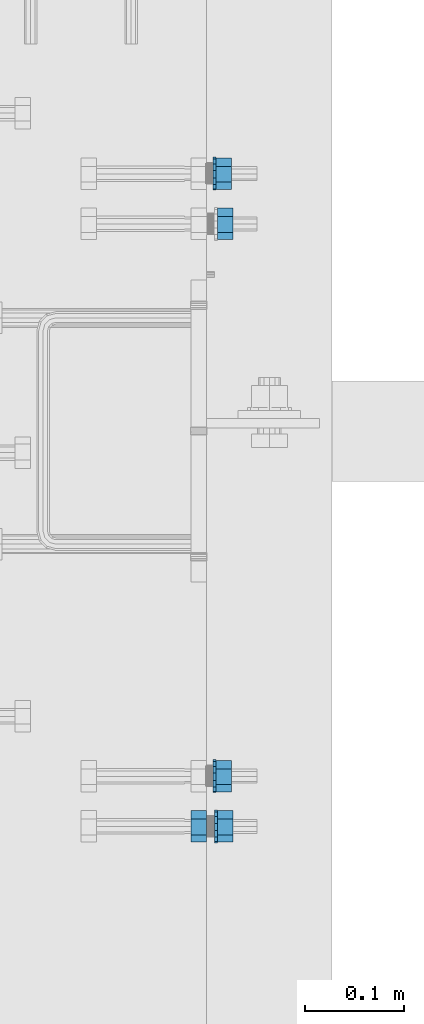
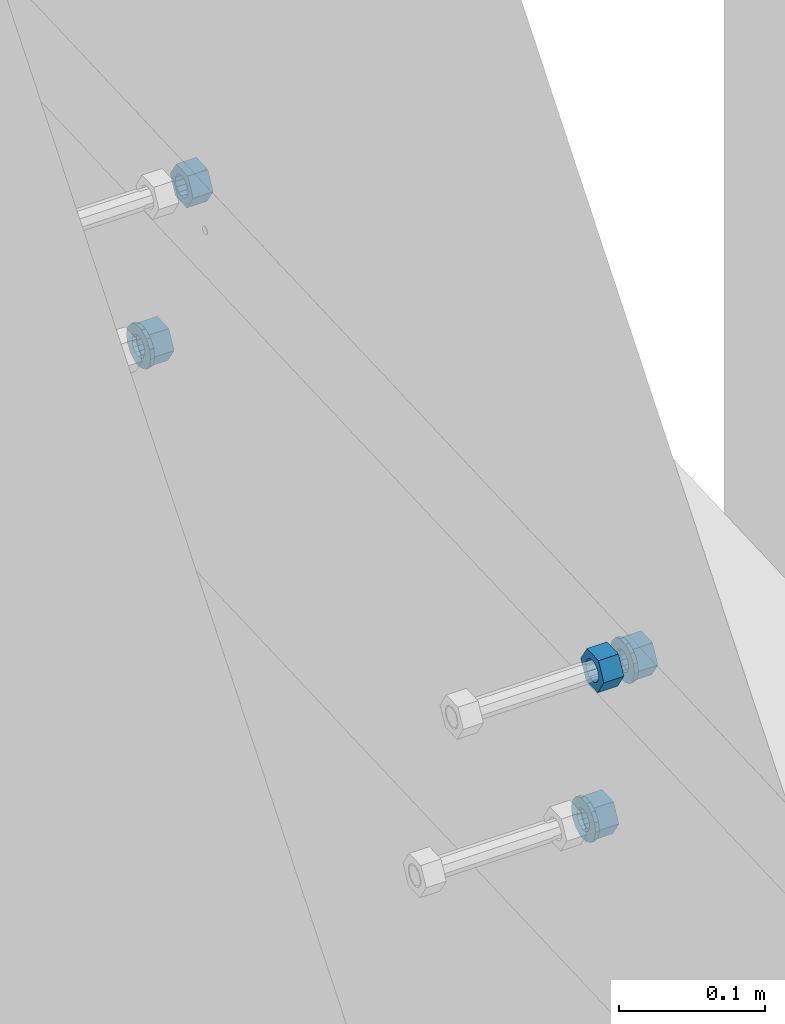
# One storey, part 717 of 975: 8 beams.
"""IFC2X3 building model written with IfcOpenShell, lengths in millimetres."""

from ifc_helpers import new_model, si_unit, frame, origin_with_axes, place, context, subcontext, project, spatial, faceted_brep, material, type_object, element, save


model = new_model("IFC2X3")

# Units and contexts
model_context = context("Model", 3, precision=1e-05, world=origin_with_axes())
body_context = subcontext(model_context, "Body", "Model", "MODEL_VIEW")
ifc_project = project(units=[si_unit("LENGTHUNIT", "METRE", prefix="MILLI"), si_unit("AREAUNIT", "SQUARE_METRE"), si_unit("VOLUMEUNIT", "CUBIC_METRE"), si_unit("MASSUNIT", "GRAM", prefix="KILO"), si_unit("TIMEUNIT", "SECOND"), si_unit("PLANEANGLEUNIT", "RADIAN"), si_unit("SOLIDANGLEUNIT", "STERADIAN"), si_unit("THERMODYNAMICTEMPERATUREUNIT", "DEGREE_CELSIUS"), si_unit("LUMINOUSINTENSITYUNIT", "LUMEN")], contexts=[model_context])

# Site, building, storey
site_placement = place(None, origin_with_axes())
site = spatial("IfcSite", under=ifc_project, at=site_placement, CompositionType="ELEMENT")
building_placement = place(site_placement, origin_with_axes())
building = spatial("IfcBuilding", under=site, at=building_placement, Name="Undefined", CompositionType="ELEMENT")
storey_placement = place(building_placement, origin_with_axes())
storey = spatial("IfcBuildingStorey", under=building, at=storey_placement, Name="Undefined", CompositionType="ELEMENT", Elevation=0.0)

# Beams
ifc_material_1 = material(Name="STEEL/F1554-36")
beam_type_1 = type_object("IfcBeamType", Name="5/8_HEAVY_HEX_NUT", PredefinedType="NOTDEFINED")
beam_1_placement = place(storey_placement, frame((29986.2872319715, 2821.85900178014, 7106.48806988909), z_axis=(-7.0905516622588e-09, -0.0430877640020049, 0.999071291046494), x_axis=(-0.999999999999998, 6.90000001668524e-08, 0.0)))
element("IfcBeam", 1, at=beam_1_placement, inside=storey, type_object=beam_type_1, material=ifc_material_1, Name="HEADED_ANCHOR_BOLT", ObjectType="5/8_HEAVY_HEX_NUT", context=body_context, shape_type="Brep", body=[
    faceted_brep([(-1.09139364212751e-11, -15.8800001144436, -2.72848410531878e-12), (1.45519152283669e-11, -7.94000005722046, -13.7500000000036), (15.8750000000146, -7.94000005722137, -13.7500000000045), (15.8749999999891, -15.8800001144446, -2.72848410531878e-12), (2.91038304567337e-11, 7.94000005722319, -13.7500000000027), (15.8750000000291, 7.94000005722319, -13.7500000000027), (2.18278728425503e-11, 15.8800001144436, 9.09494701772928e-13), (15.8750000000218, 15.8800001144427, 9.09494701772928e-13), (-7.27595761418343e-12, 7.94000005722046, 13.7500000000027), (15.8749999999927, 7.94000005722046, 13.7500000000027), (-2.18278728425503e-11, -7.94000005722228, 13.7500000000009), (15.8749999999782, -7.94000005722319, 13.7500000000009), (-7.27595761418343e-12, 0.0, 8.72999954223724), (0.0, 3.78780484388062, 7.86545780435881), (15.875, 3.78780484387971, 7.86545780435881), (15.8749999999927, -9.09494701772928e-13, 8.72999954223724), (7.27595761418343e-12, 6.82538848405238, 5.44306568481716), (15.8750000000073, 6.82538848405238, 5.44306568481716), (1.09139364212751e-11, 8.51112022706275, 1.94260765157742), (15.8750000000109, 8.51112022706093, 1.94260765157651), (1.45519152283669e-11, 8.51112022706184, -1.94260765157651), (15.8750000000146, 8.51112022706184, -1.94260765157651), (2.18278728425503e-11, 6.8253884840542, -5.44306568481716), (15.8750000000218, 6.82538848405238, -5.44306568481716), (1.81898940354586e-11, 3.78780484388153, -7.86545780435881), (15.8750000000182, 3.78780484388062, -7.86545780435881), (1.81898940354586e-11, 9.09494701772928e-13, -8.72999954223997), (15.8750000000182, 9.09494701772928e-13, -8.72999954223997), (1.09139364212751e-11, -3.78780484387971, -7.86545780436063), (15.8750000000109, -3.78780484388062, -7.86545780436063), (3.63797880709171e-12, -6.82538848405238, -5.44306568481807), (15.8750000000036, -6.82538848405329, -5.44306568481807), (0.0, -8.51112022706184, -1.94260765157833), (15.875, -8.51112022706184, -1.94260765157833), (-7.27595761418343e-12, -8.51112022706184, 1.9426076515756), (15.8749999999927, -8.51112022706275, 1.9426076515756), (-1.09139364212751e-11, -6.82538848405329, 5.44306568481534), (15.8749999999927, -6.8253884840542, 5.44306568481534), (-7.27595761418343e-12, -3.78780484388062, 7.8654578043579), (15.8749999999927, -3.78780484388153, 7.8654578043579)], [[[0, 1, 2, 3]], [[1, 4, 5, 2]], [[4, 6, 7, 5]], [[6, 8, 9, 7]], [[8, 10, 11, 9]], [[10, 0, 3, 11]], [[12, 13, 14, 15]], [[13, 16, 17, 14]], [[16, 18, 19, 17]], [[18, 20, 21, 19]], [[20, 22, 23, 21]], [[22, 24, 25, 23]], [[24, 26, 27, 25]], [[26, 28, 29, 27]], [[28, 30, 31, 29]], [[30, 32, 33, 31]], [[32, 34, 35, 33]], [[34, 36, 37, 35]], [[36, 38, 39, 37]], [[38, 12, 15, 39]], [[5, 7, 9, 11, 3, 2], [17, 19, 21, 23, 25, 27, 29, 31, 33, 35, 37, 39, 15, 14]], [[10, 8, 6, 4, 1, 0], [38, 36, 34, 32, 30, 28, 26, 24, 22, 20, 18, 16, 13, 12]]]),
])
beam_2_placement = place(storey_placement, frame((29959.2997837873, 2212.82505215651, 7080.22176473378), z_axis=(3.96407267544419e-09, 0.0430877640020053, -0.999071291046494), x_axis=(-0.999999999999998, 6.90000001668524e-08, 0.0)))
element("IfcBeam", 2, at=beam_2_placement, inside=storey, type_object=beam_type_1, material=ifc_material_1, Name="HEADED_ANCHOR_BOLT", ObjectType="5/8_HEAVY_HEX_NUT", context=body_context, shape_type="Brep", body=[
    faceted_brep([(-1.09139364212751e-11, -15.8800001144436, -2.72848410531878e-12), (1.45519152283669e-11, -7.94000005722046, -13.7500000000036), (15.8750000000146, -7.94000005722137, -13.7500000000045), (15.8749999999891, -15.8800001144446, -2.72848410531878e-12), (2.91038304567337e-11, 7.94000005722319, -13.7500000000027), (15.8750000000291, 7.94000005722319, -13.7500000000027), (2.18278728425503e-11, 15.8800001144436, 9.09494701772928e-13), (15.8750000000218, 15.8800001144427, 9.09494701772928e-13), (-7.27595761418343e-12, 7.94000005722046, 13.7500000000027), (15.8749999999927, 7.94000005722046, 13.7500000000027), (-2.18278728425503e-11, -7.94000005722228, 13.7500000000009), (15.8749999999782, -7.94000005722319, 13.7500000000009), (-7.27595761418343e-12, 0.0, 8.72999954223724), (0.0, 3.78780484388062, 7.86545780435881), (15.875, 3.78780484387971, 7.86545780435881), (15.8749999999927, -9.09494701772928e-13, 8.72999954223724), (7.27595761418343e-12, 6.82538848405238, 5.44306568481716), (15.8750000000073, 6.82538848405238, 5.44306568481716), (1.09139364212751e-11, 8.51112022706275, 1.94260765157742), (15.8750000000109, 8.51112022706093, 1.94260765157651), (1.45519152283669e-11, 8.51112022706184, -1.94260765157651), (15.8750000000146, 8.51112022706184, -1.94260765157651), (2.18278728425503e-11, 6.8253884840542, -5.44306568481716), (15.8750000000218, 6.82538848405238, -5.44306568481716), (1.81898940354586e-11, 3.78780484388153, -7.86545780435881), (15.8750000000182, 3.78780484388062, -7.86545780435881), (1.81898940354586e-11, 9.09494701772928e-13, -8.72999954223997), (15.8750000000182, 9.09494701772928e-13, -8.72999954223997), (1.09139364212751e-11, -3.78780484387971, -7.86545780436063), (15.8750000000109, -3.78780484388062, -7.86545780436063), (3.63797880709171e-12, -6.82538848405238, -5.44306568481807), (15.8750000000036, -6.82538848405329, -5.44306568481807), (0.0, -8.51112022706184, -1.94260765157833), (15.875, -8.51112022706184, -1.94260765157833), (-7.27595761418343e-12, -8.51112022706184, 1.9426076515756), (15.8749999999927, -8.51112022706275, 1.9426076515756), (-1.09139364212751e-11, -6.82538848405329, 5.44306568481534), (15.8749999999927, -6.8253884840542, 5.44306568481534), (-7.27595761418343e-12, -3.78780484388062, 7.8654578043579), (15.8749999999927, -3.78780484388153, 7.8654578043579)], [[[0, 1, 2, 3]], [[1, 4, 5, 2]], [[4, 6, 7, 5]], [[6, 8, 9, 7]], [[8, 10, 11, 9]], [[10, 0, 3, 11]], [[12, 13, 14, 15]], [[13, 16, 17, 14]], [[16, 18, 19, 17]], [[18, 20, 21, 19]], [[20, 22, 23, 21]], [[22, 24, 25, 23]], [[24, 26, 27, 25]], [[26, 28, 29, 27]], [[28, 30, 31, 29]], [[30, 32, 33, 31]], [[32, 34, 35, 33]], [[34, 36, 37, 35]], [[36, 38, 39, 37]], [[38, 12, 15, 39]], [[5, 7, 9, 11, 3, 2], [17, 19, 21, 23, 25, 27, 29, 31, 33, 35, 37, 39, 15, 14]], [[10, 8, 6, 4, 1, 0], [38, 36, 34, 32, 30, 28, 26, 24, 22, 20, 18, 16, 13, 12]]]),
])
beam_3_placement = place(storey_placement, frame((29986.2872837876, 2212.82505200955, 7080.22176468678), z_axis=(3.96407267544419e-09, 0.0430877640020053, -0.999071291046494), x_axis=(-0.999999999999998, 6.90000001668524e-08, 0.0)))
element("IfcBeam", 3, at=beam_3_placement, inside=storey, type_object=beam_type_1, material=ifc_material_1, Name="HEADED_ANCHOR_BOLT", ObjectType="5/8_HEAVY_HEX_NUT", context=body_context, shape_type="Brep", body=[
    faceted_brep([(-1.09139364212751e-11, -15.8800001144436, -2.72848410531878e-12), (1.45519152283669e-11, -7.94000005722046, -13.7500000000036), (15.8750000000146, -7.94000005722137, -13.7500000000045), (15.8749999999891, -15.8800001144446, -2.72848410531878e-12), (2.91038304567337e-11, 7.94000005722319, -13.7500000000027), (15.8750000000291, 7.94000005722319, -13.7500000000027), (2.18278728425503e-11, 15.8800001144436, 9.09494701772928e-13), (15.8750000000218, 15.8800001144427, 9.09494701772928e-13), (-7.27595761418343e-12, 7.94000005722046, 13.7500000000027), (15.8749999999927, 7.94000005722046, 13.7500000000027), (-2.18278728425503e-11, -7.94000005722228, 13.7500000000009), (15.8749999999782, -7.94000005722319, 13.7500000000009), (-7.27595761418343e-12, 0.0, 8.72999954223724), (0.0, 3.78780484388062, 7.86545780435881), (15.875, 3.78780484387971, 7.86545780435881), (15.8749999999927, -9.09494701772928e-13, 8.72999954223724), (7.27595761418343e-12, 6.82538848405238, 5.44306568481716), (15.8750000000073, 6.82538848405238, 5.44306568481716), (1.09139364212751e-11, 8.51112022706275, 1.94260765157742), (15.8750000000109, 8.51112022706093, 1.94260765157651), (1.45519152283669e-11, 8.51112022706184, -1.94260765157651), (15.8750000000146, 8.51112022706184, -1.94260765157651), (2.18278728425503e-11, 6.8253884840542, -5.44306568481716), (15.8750000000218, 6.82538848405238, -5.44306568481716), (1.81898940354586e-11, 3.78780484388153, -7.86545780435881), (15.8750000000182, 3.78780484388062, -7.86545780435881), (1.81898940354586e-11, 9.09494701772928e-13, -8.72999954223997), (15.8750000000182, 9.09494701772928e-13, -8.72999954223997), (1.09139364212751e-11, -3.78780484387971, -7.86545780436063), (15.8750000000109, -3.78780484388062, -7.86545780436063), (3.63797880709171e-12, -6.82538848405238, -5.44306568481807), (15.8750000000036, -6.82538848405329, -5.44306568481807), (0.0, -8.51112022706184, -1.94260765157833), (15.875, -8.51112022706184, -1.94260765157833), (-7.27595761418343e-12, -8.51112022706184, 1.9426076515756), (15.8749999999927, -8.51112022706275, 1.9426076515756), (-1.09139364212751e-11, -6.82538848405329, 5.44306568481534), (15.8749999999927, -6.8253884840542, 5.44306568481534), (-7.27595761418343e-12, -3.78780484388062, 7.8654578043579), (15.8749999999927, -3.78780484388153, 7.8654578043579)], [[[0, 1, 2, 3]], [[1, 4, 5, 2]], [[4, 6, 7, 5]], [[6, 8, 9, 7]], [[8, 10, 11, 9]], [[10, 0, 3, 11]], [[12, 13, 14, 15]], [[13, 16, 17, 14]], [[16, 18, 19, 17]], [[18, 20, 21, 19]], [[20, 22, 23, 21]], [[22, 24, 25, 23]], [[24, 26, 27, 25]], [[26, 28, 29, 27]], [[28, 30, 31, 29]], [[30, 32, 33, 31]], [[32, 34, 35, 33]], [[34, 36, 37, 35]], [[36, 38, 39, 37]], [[38, 12, 15, 39]], [[5, 7, 9, 11, 3, 2], [17, 19, 21, 23, 25, 27, 29, 31, 33, 35, 37, 39, 15, 14]], [[10, 8, 6, 4, 1, 0], [38, 36, 34, 32, 30, 28, 26, 24, 22, 20, 18, 16, 13, 12]]]),
])
ifc_material_2 = material(Name="STEEL/A36")
beam_4_placement = place(storey_placement, frame((29984.6998825615, 2872.60235520346, 6943.42304752684), z_axis=(-7.0905516622588e-09, -0.0430877640020049, 0.999071291046494), x_axis=(-0.999999999999998, 6.90000001668524e-08, 0.0)))
element("IfcBeam", 4, at=beam_4_placement, inside=storey, type_object=beam_type_1, material=ifc_material_2, Name="NUT", ObjectType="5/8_HEAVY_HEX_NUT", context=body_context, shape_type="Brep", body=[
    faceted_brep([(-1.09139364212751e-11, -15.8800001144436, -2.72848410531878e-12), (1.45519152283669e-11, -7.94000005722046, -13.7500000000036), (15.8750000000146, -7.94000005722137, -13.7500000000045), (15.8749999999891, -15.8800001144446, -2.72848410531878e-12), (2.91038304567337e-11, 7.94000005722319, -13.7500000000027), (15.8750000000291, 7.94000005722319, -13.7500000000027), (2.18278728425503e-11, 15.8800001144436, 9.09494701772928e-13), (15.8750000000218, 15.8800001144427, 9.09494701772928e-13), (-7.27595761418343e-12, 7.94000005722046, 13.7500000000027), (15.8749999999927, 7.94000005722046, 13.7500000000027), (-2.18278728425503e-11, -7.94000005722228, 13.7500000000009), (15.8749999999782, -7.94000005722319, 13.7500000000009), (-7.27595761418343e-12, 0.0, 8.72999954223724), (0.0, 3.78780484388062, 7.86545780435881), (15.875, 3.78780484387971, 7.86545780435881), (15.8749999999927, -9.09494701772928e-13, 8.72999954223724), (7.27595761418343e-12, 6.82538848405238, 5.44306568481716), (15.8750000000073, 6.82538848405238, 5.44306568481716), (1.09139364212751e-11, 8.51112022706275, 1.94260765157742), (15.8750000000109, 8.51112022706093, 1.94260765157651), (1.45519152283669e-11, 8.51112022706184, -1.94260765157651), (15.8750000000146, 8.51112022706184, -1.94260765157651), (2.18278728425503e-11, 6.8253884840542, -5.44306568481716), (15.8750000000218, 6.82538848405238, -5.44306568481716), (1.81898940354586e-11, 3.78780484388153, -7.86545780435881), (15.8750000000182, 3.78780484388062, -7.86545780435881), (1.81898940354586e-11, 9.09494701772928e-13, -8.72999954223997), (15.8750000000182, 9.09494701772928e-13, -8.72999954223997), (1.09139364212751e-11, -3.78780484387971, -7.86545780436063), (15.8750000000109, -3.78780484388062, -7.86545780436063), (3.63797880709171e-12, -6.82538848405238, -5.44306568481807), (15.8750000000036, -6.82538848405329, -5.44306568481807), (0.0, -8.51112022706184, -1.94260765157833), (15.875, -8.51112022706184, -1.94260765157833), (-7.27595761418343e-12, -8.51112022706184, 1.9426076515756), (15.8749999999927, -8.51112022706275, 1.9426076515756), (-1.09139364212751e-11, -6.82538848405329, 5.44306568481534), (15.8749999999927, -6.8253884840542, 5.44306568481534), (-7.27595761418343e-12, -3.78780484388062, 7.8654578043579), (15.8749999999927, -3.78780484388153, 7.8654578043579)], [[[0, 1, 2, 3]], [[1, 4, 5, 2]], [[4, 6, 7, 5]], [[6, 8, 9, 7]], [[8, 10, 11, 9]], [[10, 0, 3, 11]], [[12, 13, 14, 15]], [[13, 16, 17, 14]], [[16, 18, 19, 17]], [[18, 20, 21, 19]], [[20, 22, 23, 21]], [[22, 24, 25, 23]], [[24, 26, 27, 25]], [[26, 28, 29, 27]], [[28, 30, 31, 29]], [[30, 32, 33, 31]], [[32, 34, 35, 33]], [[34, 36, 37, 35]], [[36, 38, 39, 37]], [[38, 12, 15, 39]], [[5, 7, 9, 11, 3, 2], [17, 19, 21, 23, 25, 27, 29, 31, 33, 35, 37, 39, 15, 14]], [[10, 8, 6, 4, 1, 0], [38, 36, 34, 32, 30, 28, 26, 24, 22, 20, 18, 16, 13, 12]]]),
])
beam_5_placement = place(storey_placement, frame((29984.6998667138, 2263.56849618155, 6917.15674659125), z_axis=(-7.0905516622588e-09, -0.0430877640020049, 0.999071291046494), x_axis=(-0.999999999999998, 6.90000001668524e-08, 0.0)))
element("IfcBeam", 5, at=beam_5_placement, inside=storey, type_object=beam_type_1, material=ifc_material_2, Name="NUT", ObjectType="5/8_HEAVY_HEX_NUT", context=body_context, shape_type="Brep", body=[
    faceted_brep([(-1.09139364212751e-11, -15.8800001144436, -2.72848410531878e-12), (1.45519152283669e-11, -7.94000005722046, -13.7500000000036), (15.8750000000146, -7.94000005722137, -13.7500000000045), (15.8749999999891, -15.8800001144446, -2.72848410531878e-12), (2.91038304567337e-11, 7.94000005722319, -13.7500000000027), (15.8750000000291, 7.94000005722319, -13.7500000000027), (2.18278728425503e-11, 15.8800001144436, 9.09494701772928e-13), (15.8750000000218, 15.8800001144427, 9.09494701772928e-13), (-7.27595761418343e-12, 7.94000005722046, 13.7500000000027), (15.8749999999927, 7.94000005722046, 13.7500000000027), (-2.18278728425503e-11, -7.94000005722228, 13.7500000000009), (15.8749999999782, -7.94000005722319, 13.7500000000009), (-7.27595761418343e-12, 0.0, 8.72999954223724), (0.0, 3.78780484388062, 7.86545780435881), (15.875, 3.78780484387971, 7.86545780435881), (15.8749999999927, -9.09494701772928e-13, 8.72999954223724), (7.27595761418343e-12, 6.82538848405238, 5.44306568481716), (15.8750000000073, 6.82538848405238, 5.44306568481716), (1.09139364212751e-11, 8.51112022706275, 1.94260765157742), (15.8750000000109, 8.51112022706093, 1.94260765157651), (1.45519152283669e-11, 8.51112022706184, -1.94260765157651), (15.8750000000146, 8.51112022706184, -1.94260765157651), (2.18278728425503e-11, 6.8253884840542, -5.44306568481716), (15.8750000000218, 6.82538848405238, -5.44306568481716), (1.81898940354586e-11, 3.78780484388153, -7.86545780435881), (15.8750000000182, 3.78780484388062, -7.86545780435881), (1.81898940354586e-11, 9.09494701772928e-13, -8.72999954223997), (15.8750000000182, 9.09494701772928e-13, -8.72999954223997), (1.09139364212751e-11, -3.78780484387971, -7.86545780436063), (15.8750000000109, -3.78780484388062, -7.86545780436063), (3.63797880709171e-12, -6.82538848405238, -5.44306568481807), (15.8750000000036, -6.82538848405329, -5.44306568481807), (0.0, -8.51112022706184, -1.94260765157833), (15.875, -8.51112022706184, -1.94260765157833), (-7.27595761418343e-12, -8.51112022706184, 1.9426076515756), (15.8749999999927, -8.51112022706275, 1.9426076515756), (-1.09139364212751e-11, -6.82538848405329, 5.44306568481534), (15.8749999999927, -6.8253884840542, 5.44306568481534), (-7.27595761418343e-12, -3.78780484388062, 7.8654578043579), (15.8749999999927, -3.78780484388153, 7.8654578043579)], [[[0, 1, 2, 3]], [[1, 4, 5, 2]], [[4, 6, 7, 5]], [[6, 8, 9, 7]], [[8, 10, 11, 9]], [[10, 0, 3, 11]], [[12, 13, 14, 15]], [[13, 16, 17, 14]], [[16, 18, 19, 17]], [[18, 20, 21, 19]], [[20, 22, 23, 21]], [[22, 24, 25, 23]], [[24, 26, 27, 25]], [[26, 28, 29, 27]], [[28, 30, 31, 29]], [[30, 32, 33, 31]], [[32, 34, 35, 33]], [[34, 36, 37, 35]], [[36, 38, 39, 37]], [[38, 12, 15, 39]], [[5, 7, 9, 11, 3, 2], [17, 19, 21, 23, 25, 27, 29, 31, 33, 35, 37, 39, 15, 14]], [[10, 8, 6, 4, 1, 0], [38, 36, 34, 32, 30, 28, 26, 24, 22, 20, 18, 16, 13, 12]]]),
])
beam_type_2 = type_object("IfcBeamType", Name="5/8_WASHER", PredefinedType="NOTDEFINED")
beam_6_placement = place(storey_placement, frame((29970.4122837877, 2212.82505215104, 7080.22176466474), z_axis=(3.96407267544419e-09, 0.0430877640020053, -0.999071291046494), x_axis=(-0.999999999999998, 6.90000001668524e-08, 0.0)))
element("IfcBeam", 6, at=beam_6_placement, inside=storey, type_object=beam_type_2, material=ifc_material_1, Name="HEADED_ANCHOR_BOLT", ObjectType="5/8_WASHER", context=body_context, shape_type="Brep", body=[
    faceted_brep([(1.09139364212751e-11, -16.670000076293, -2.72848410531878e-12), (2.18278728425503e-11, -15.0191510966704, -7.23284196419536), (3.1750000000211, -15.0191510966711, -7.23284196419627), (3.17500000001019, -16.6700000762937, -1.81898940354586e-12), (2.91038304567337e-11, -10.3935750445523, -13.0331308723944), (3.17500000002838, -10.3935750445526, -13.0331308723953), (2.91038304567337e-11, -3.70942398602756, -16.2520483704566), (3.17500000002838, -3.70942398602779, -16.2520483704566), (2.5465851649642e-11, 3.70942398602961, -16.2520483704557), (3.17500000002474, 3.70942398602961, -16.2520483704566), (1.45519152283669e-11, 10.3935750445542, -13.0331308723935), (3.17500000001382, 10.3935750445537, -13.0331308723944), (0.0, 15.0191510966717, -7.23284196419354), (3.17499999999927, 15.0191510966713, -7.23284196419354), (-7.27595761418343e-12, 16.6700000762933, 0.0), (3.174999999992, 16.6700000762928, -9.09494701772928e-13), (-1.81898940354586e-11, 15.0191510966706, 7.23284196419354), (3.17499999998108, 15.0191510966704, 7.23284196419354), (-2.5465851649642e-11, 10.3935750445519, 13.0331308723926), (3.17499999997381, 10.3935750445517, 13.0331308723926), (-2.5465851649642e-11, 3.70942398602733, 16.2520483704538), (3.17499999997381, 3.7094239860271, 16.2520483704529), (-2.18278728425503e-11, -3.70942398602983, 16.2520483704529), (3.17499999997744, -3.70942398603006, 16.2520483704538), (-1.09139364212751e-11, -10.3935750445542, 13.0331308723908), (3.17499999998836, -10.3935750445544, 13.0331308723908), (0.0, -15.0191510966717, 7.23284196419172), (3.17499999999927, -15.019151096672, 7.23284196419081), (-7.27595761418343e-12, 0.0, 8.72999954223724), (0.0, 3.78780484388062, 7.86545780435881), (3.17499999998472, 3.78780484387903, 7.86545780435699), (3.17499999998836, -9.09494701772928e-13, 8.72999954223542), (7.27595761418343e-12, 6.82538848405238, 5.44306568481716), (3.17499999998836, 6.82538848405102, 5.44306568481534), (1.09139364212751e-11, 8.51112022706275, 1.94260765157742), (3.174999999992, 8.51112022705979, 1.94260765157651), (1.45519152283669e-11, 8.51112022706184, -1.94260765157651), (3.17499999999563, 8.51112022706025, -1.94260765157742), (2.18278728425503e-11, 6.8253884840542, -5.44306568481716), (3.17500000000655, 6.8253884840517, -5.44306568481807), (1.81898940354586e-11, 3.78780484388153, -7.86545780435881), (3.17500000001019, 3.78780484388017, -7.86545780435972), (1.81898940354586e-11, 9.09494701772928e-13, -8.72999954223997), (3.17500000001382, 6.82121026329696e-13, -8.72999954223997), (1.09139364212751e-11, -3.78780484387971, -7.86545780436063), (3.17500000001382, -3.78780484387994, -7.86545780436063), (3.63797880709171e-12, -6.82538848405238, -5.44306568481807), (3.17500000001019, -6.82538848405147, -5.44306568481898), (0.0, -8.51112022706184, -1.94260765157833), (3.17500000001019, -8.5111202270607, -1.94260765157924), (-7.27595761418343e-12, -8.51112022706184, 1.9426076515756), (3.17500000000291, -8.51112022706093, 1.94260765157469), (-1.09139364212751e-11, -6.82538848405329, 5.44306568481534), (3.17499999999563, -6.82538848405238, 5.44306568481534), (-7.27595761418343e-12, -3.78780484388062, 7.8654578043579), (3.174999999992, -3.78780484388085, 7.86545780435699)], [[[0, 1, 2, 3]], [[1, 4, 5, 2]], [[4, 6, 7, 5]], [[6, 8, 9, 7]], [[8, 10, 11, 9]], [[10, 12, 13, 11]], [[12, 14, 15, 13]], [[14, 16, 17, 15]], [[16, 18, 19, 17]], [[18, 20, 21, 19]], [[20, 22, 23, 21]], [[22, 24, 25, 23]], [[24, 26, 27, 25]], [[26, 0, 3, 27]], [[28, 29, 30, 31]], [[29, 32, 33, 30]], [[32, 34, 35, 33]], [[34, 36, 37, 35]], [[36, 38, 39, 37]], [[38, 40, 41, 39]], [[40, 42, 43, 41]], [[42, 44, 45, 43]], [[44, 46, 47, 45]], [[46, 48, 49, 47]], [[48, 50, 51, 49]], [[50, 52, 53, 51]], [[52, 54, 55, 53]], [[54, 28, 31, 55]], [[5, 7, 9, 11, 13, 15, 17, 19, 21, 23, 25, 27, 3, 2], [33, 35, 37, 39, 41, 43, 45, 47, 49, 51, 53, 55, 31, 30]], [[26, 24, 22, 20, 18, 16, 14, 12, 10, 8, 6, 4, 1, 0], [54, 52, 50, 48, 46, 44, 42, 40, 38, 36, 34, 32, 29, 28]]]),
])
beam_7_placement = place(storey_placement, frame((29968.8248825615, 2872.60235707569, 6943.42304758977), z_axis=(-7.0905516622588e-09, -0.0430877640020049, 0.999071291046494), x_axis=(-0.999999999999998, 6.90000001668524e-08, 0.0)))
element("IfcBeam", 7, at=beam_7_placement, inside=storey, type_object=beam_type_2, material=ifc_material_2, Name="WASHER", ObjectType="5/8_WASHER", context=body_context, shape_type="Brep", body=[
    faceted_brep([(1.09139364212751e-11, -16.670000076293, -2.72848410531878e-12), (2.18278728425503e-11, -15.0191510966704, -7.23284196419536), (3.1750000000211, -15.0191510966711, -7.23284196419627), (3.17500000001019, -16.6700000762937, -1.81898940354586e-12), (2.91038304567337e-11, -10.3935750445523, -13.0331308723944), (3.17500000002838, -10.3935750445526, -13.0331308723953), (2.91038304567337e-11, -3.70942398602756, -16.2520483704566), (3.17500000002838, -3.70942398602779, -16.2520483704566), (2.5465851649642e-11, 3.70942398602961, -16.2520483704557), (3.17500000002474, 3.70942398602961, -16.2520483704566), (1.45519152283669e-11, 10.3935750445542, -13.0331308723935), (3.17500000001382, 10.3935750445537, -13.0331308723944), (0.0, 15.0191510966717, -7.23284196419354), (3.17499999999927, 15.0191510966713, -7.23284196419354), (-7.27595761418343e-12, 16.6700000762933, 0.0), (3.174999999992, 16.6700000762928, -9.09494701772928e-13), (-1.81898940354586e-11, 15.0191510966706, 7.23284196419354), (3.17499999998108, 15.0191510966704, 7.23284196419354), (-2.5465851649642e-11, 10.3935750445519, 13.0331308723926), (3.17499999997381, 10.3935750445517, 13.0331308723926), (-2.5465851649642e-11, 3.70942398602733, 16.2520483704538), (3.17499999997381, 3.7094239860271, 16.2520483704529), (-2.18278728425503e-11, -3.70942398602983, 16.2520483704529), (3.17499999997744, -3.70942398603006, 16.2520483704538), (-1.09139364212751e-11, -10.3935750445542, 13.0331308723908), (3.17499999998836, -10.3935750445544, 13.0331308723908), (0.0, -15.0191510966717, 7.23284196419172), (3.17499999999927, -15.019151096672, 7.23284196419081), (-7.27595761418343e-12, 0.0, 8.72999954223724), (0.0, 3.78780484388062, 7.86545780435881), (3.17499999998472, 3.78780484387903, 7.86545780435699), (3.17499999998836, -9.09494701772928e-13, 8.72999954223542), (7.27595761418343e-12, 6.82538848405238, 5.44306568481716), (3.17499999998836, 6.82538848405102, 5.44306568481534), (1.09139364212751e-11, 8.51112022706275, 1.94260765157742), (3.174999999992, 8.51112022705979, 1.94260765157651), (1.45519152283669e-11, 8.51112022706184, -1.94260765157651), (3.17499999999563, 8.51112022706025, -1.94260765157742), (2.18278728425503e-11, 6.8253884840542, -5.44306568481716), (3.17500000000655, 6.8253884840517, -5.44306568481807), (1.81898940354586e-11, 3.78780484388153, -7.86545780435881), (3.17500000001019, 3.78780484388017, -7.86545780435972), (1.81898940354586e-11, 9.09494701772928e-13, -8.72999954223997), (3.17500000001382, 6.82121026329696e-13, -8.72999954223997), (1.09139364212751e-11, -3.78780484387971, -7.86545780436063), (3.17500000001382, -3.78780484387994, -7.86545780436063), (3.63797880709171e-12, -6.82538848405238, -5.44306568481807), (3.17500000001019, -6.82538848405147, -5.44306568481898), (0.0, -8.51112022706184, -1.94260765157833), (3.17500000001019, -8.5111202270607, -1.94260765157924), (-7.27595761418343e-12, -8.51112022706184, 1.9426076515756), (3.17500000000291, -8.51112022706093, 1.94260765157469), (-1.09139364212751e-11, -6.82538848405329, 5.44306568481534), (3.17499999999563, -6.82538848405238, 5.44306568481534), (-7.27595761418343e-12, -3.78780484388062, 7.8654578043579), (3.174999999992, -3.78780484388085, 7.86545780435699)], [[[0, 1, 2, 3]], [[1, 4, 5, 2]], [[4, 6, 7, 5]], [[6, 8, 9, 7]], [[8, 10, 11, 9]], [[10, 12, 13, 11]], [[12, 14, 15, 13]], [[14, 16, 17, 15]], [[16, 18, 19, 17]], [[18, 20, 21, 19]], [[20, 22, 23, 21]], [[22, 24, 25, 23]], [[24, 26, 27, 25]], [[26, 0, 3, 27]], [[28, 29, 30, 31]], [[29, 32, 33, 30]], [[32, 34, 35, 33]], [[34, 36, 37, 35]], [[36, 38, 39, 37]], [[38, 40, 41, 39]], [[40, 42, 43, 41]], [[42, 44, 45, 43]], [[44, 46, 47, 45]], [[46, 48, 49, 47]], [[48, 50, 51, 49]], [[50, 52, 53, 51]], [[52, 54, 55, 53]], [[54, 28, 31, 55]], [[5, 7, 9, 11, 13, 15, 17, 19, 21, 23, 25, 27, 3, 2], [33, 35, 37, 39, 41, 43, 45, 47, 49, 51, 53, 55, 31, 30]], [[26, 24, 22, 20, 18, 16, 14, 12, 10, 8, 6, 4, 1, 0], [54, 52, 50, 48, 46, 44, 42, 40, 38, 36, 34, 32, 29, 28]]]),
])
beam_8_placement = place(storey_placement, frame((29968.8248667138, 2263.56849805377, 6917.15674665419), z_axis=(-7.0905516622588e-09, -0.0430877640020049, 0.999071291046494), x_axis=(-0.999999999999998, 6.90000001668524e-08, 0.0)))
element("IfcBeam", 8, at=beam_8_placement, inside=storey, type_object=beam_type_2, material=ifc_material_2, Name="WASHER", ObjectType="5/8_WASHER", context=body_context, shape_type="Brep", body=[
    faceted_brep([(1.09139364212751e-11, -16.670000076293, -2.72848410531878e-12), (2.18278728425503e-11, -15.0191510966704, -7.23284196419536), (3.1750000000211, -15.0191510966711, -7.23284196419627), (3.17500000001019, -16.6700000762937, -1.81898940354586e-12), (2.91038304567337e-11, -10.3935750445523, -13.0331308723944), (3.17500000002838, -10.3935750445526, -13.0331308723953), (2.91038304567337e-11, -3.70942398602756, -16.2520483704566), (3.17500000002838, -3.70942398602779, -16.2520483704566), (2.5465851649642e-11, 3.70942398602961, -16.2520483704557), (3.17500000002474, 3.70942398602961, -16.2520483704566), (1.45519152283669e-11, 10.3935750445542, -13.0331308723935), (3.17500000001382, 10.3935750445537, -13.0331308723944), (0.0, 15.0191510966717, -7.23284196419354), (3.17499999999927, 15.0191510966713, -7.23284196419354), (-7.27595761418343e-12, 16.6700000762933, 0.0), (3.174999999992, 16.6700000762928, -9.09494701772928e-13), (-1.81898940354586e-11, 15.0191510966706, 7.23284196419354), (3.17499999998108, 15.0191510966704, 7.23284196419354), (-2.5465851649642e-11, 10.3935750445519, 13.0331308723926), (3.17499999997381, 10.3935750445517, 13.0331308723926), (-2.5465851649642e-11, 3.70942398602733, 16.2520483704538), (3.17499999997381, 3.7094239860271, 16.2520483704529), (-2.18278728425503e-11, -3.70942398602983, 16.2520483704529), (3.17499999997744, -3.70942398603006, 16.2520483704538), (-1.09139364212751e-11, -10.3935750445542, 13.0331308723908), (3.17499999998836, -10.3935750445544, 13.0331308723908), (0.0, -15.0191510966717, 7.23284196419172), (3.17499999999927, -15.019151096672, 7.23284196419081), (-7.27595761418343e-12, 0.0, 8.72999954223724), (0.0, 3.78780484388062, 7.86545780435881), (3.17499999998472, 3.78780484387903, 7.86545780435699), (3.17499999998836, -9.09494701772928e-13, 8.72999954223542), (7.27595761418343e-12, 6.82538848405238, 5.44306568481716), (3.17499999998836, 6.82538848405102, 5.44306568481534), (1.09139364212751e-11, 8.51112022706275, 1.94260765157742), (3.174999999992, 8.51112022705979, 1.94260765157651), (1.45519152283669e-11, 8.51112022706184, -1.94260765157651), (3.17499999999563, 8.51112022706025, -1.94260765157742), (2.18278728425503e-11, 6.8253884840542, -5.44306568481716), (3.17500000000655, 6.8253884840517, -5.44306568481807), (1.81898940354586e-11, 3.78780484388153, -7.86545780435881), (3.17500000001019, 3.78780484388017, -7.86545780435972), (1.81898940354586e-11, 9.09494701772928e-13, -8.72999954223997), (3.17500000001382, 6.82121026329696e-13, -8.72999954223997), (1.09139364212751e-11, -3.78780484387971, -7.86545780436063), (3.17500000001382, -3.78780484387994, -7.86545780436063), (3.63797880709171e-12, -6.82538848405238, -5.44306568481807), (3.17500000001019, -6.82538848405147, -5.44306568481898), (0.0, -8.51112022706184, -1.94260765157833), (3.17500000001019, -8.5111202270607, -1.94260765157924), (-7.27595761418343e-12, -8.51112022706184, 1.9426076515756), (3.17500000000291, -8.51112022706093, 1.94260765157469), (-1.09139364212751e-11, -6.82538848405329, 5.44306568481534), (3.17499999999563, -6.82538848405238, 5.44306568481534), (-7.27595761418343e-12, -3.78780484388062, 7.8654578043579), (3.174999999992, -3.78780484388085, 7.86545780435699)], [[[0, 1, 2, 3]], [[1, 4, 5, 2]], [[4, 6, 7, 5]], [[6, 8, 9, 7]], [[8, 10, 11, 9]], [[10, 12, 13, 11]], [[12, 14, 15, 13]], [[14, 16, 17, 15]], [[16, 18, 19, 17]], [[18, 20, 21, 19]], [[20, 22, 23, 21]], [[22, 24, 25, 23]], [[24, 26, 27, 25]], [[26, 0, 3, 27]], [[28, 29, 30, 31]], [[29, 32, 33, 30]], [[32, 34, 35, 33]], [[34, 36, 37, 35]], [[36, 38, 39, 37]], [[38, 40, 41, 39]], [[40, 42, 43, 41]], [[42, 44, 45, 43]], [[44, 46, 47, 45]], [[46, 48, 49, 47]], [[48, 50, 51, 49]], [[50, 52, 53, 51]], [[52, 54, 55, 53]], [[54, 28, 31, 55]], [[5, 7, 9, 11, 13, 15, 17, 19, 21, 23, 25, 27, 3, 2], [33, 35, 37, 39, 41, 43, 45, 47, 49, 51, 53, 55, 31, 30]], [[26, 24, 22, 20, 18, 16, 14, 12, 10, 8, 6, 4, 1, 0], [54, 52, 50, 48, 46, 44, 42, 40, 38, 36, 34, 32, 29, 28]]]),
])

save(model, "model.ifc")
